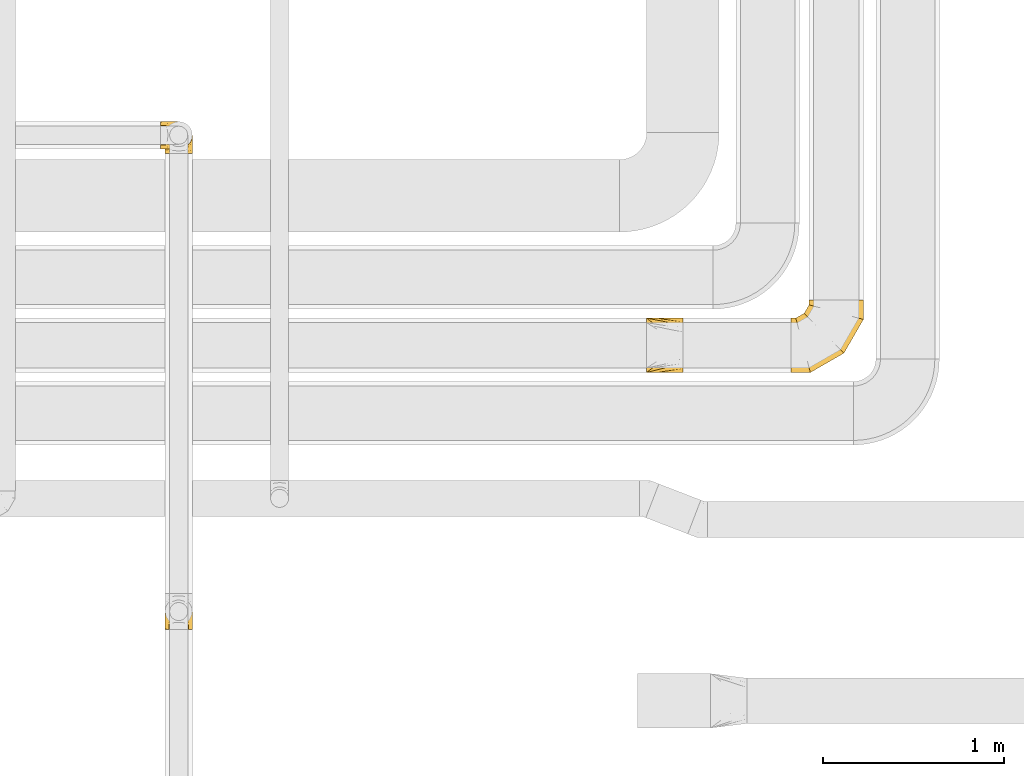
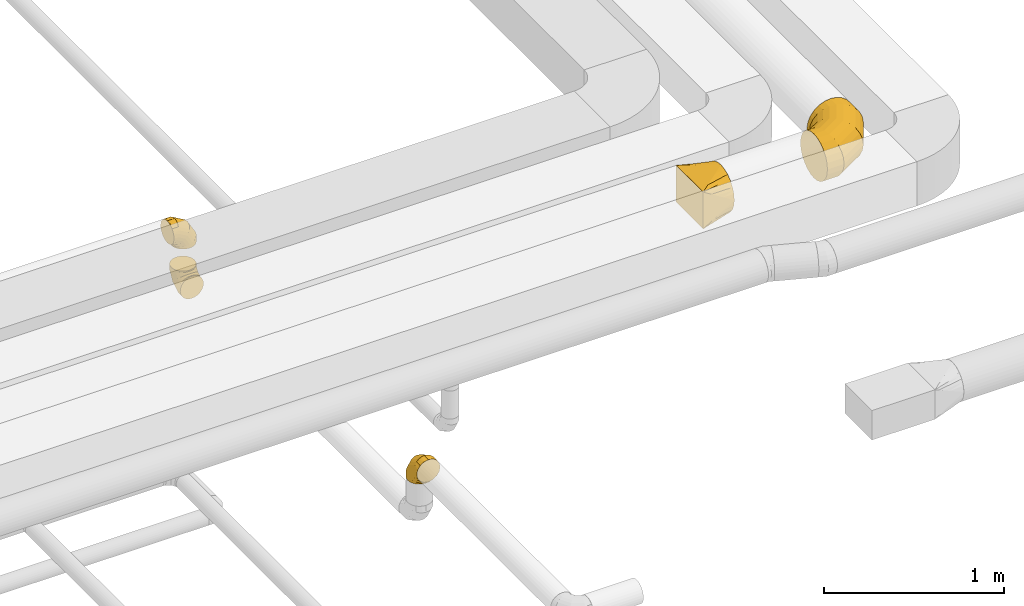
# One storey, part 10 of 92: 5 coverings.
"""IFC2X3 building model written with IfcOpenShell, lengths in millimetres."""

import ifcopenshell
import ifcopenshell.guid

model = None  # the IFC model being written
_history = None  # IfcOwnerHistory: only IFC2X3 demands one
_inside = {}  # id of a spatial element -> (the spatial element, [elements in it])
_under = {}  # id of a project, library or spatial element -> (it, [spatial elements below it])
_declared = {}  # id of a project -> (the project, [libraries it declares])
_typed = {}  # id of a type object -> (the type object, [elements of that type])
_made_of = {}  # id of a material, layer set ... -> (it, [elements and type objects made of it])


def new_model(schema):
    """Start an empty IFC model of exactly this schema.

    Asked for "IFC4X3", IfcOpenShell would pick the latest addendum, in which some entities
    have other attributes; the version numbers below select the first issue.
    IFC2X3 requires an IfcOwnerHistory on every rooted entity: one is made here for all.
    """
    global model, _history
    if schema == "IFC4X3":
        model = ifcopenshell.file(schema_version=(4, 3, 0, 0))
    else:
        model = ifcopenshell.file(schema=schema)
    _inside.clear()
    _under.clear()
    _declared.clear()
    _typed.clear()
    _made_of.clear()
    _history = None
    if model.schema == "IFC2X3":
        org = make("IfcOrganization", Name="unknown")
        user = make(
            "IfcPersonAndOrganization",
            ThePerson=make("IfcPerson", FamilyName="unknown"),
            TheOrganization=org,
        )
        app = make(
            "IfcApplication",
            ApplicationDeveloper=org,
            Version="unknown",
            ApplicationFullName="unknown",
            ApplicationIdentifier="unknown",
        )
        _history = make(
            "IfcOwnerHistory",
            OwningUser=user,
            OwningApplication=app,
            ChangeAction="ADDED",
            CreationDate=0,
        )
    return model


def make(cls, **values):
    """One entity of the class cls with the attributes given. An attribute that is None is left unset."""
    return model.create_entity(
        cls, **{name: value for name, value in values.items() if value is not None}
    )


def entity(cls, *values):
    """Any entity or typed value of the class cls, its attributes in the order of the schema. None: left unset."""
    e = model.create_entity(cls)
    for i, value in enumerate(values):
        if value is not None:
            e[i] = value
    return e


def rooted(cls, **values):
    """An entity with a GlobalId (a new one), such as an element, a storey or a relation."""
    return make(cls, GlobalId=ifcopenshell.guid.new(), OwnerHistory=_history, **values)


def si_unit(unit_type, name, prefix=None):
    """IfcSIUnit, for example si_unit("LENGTHUNIT", "METRE", prefix="MILLI")."""
    return make("IfcSIUnit", UnitType=unit_type, Prefix=prefix, Name=name)


def converted_unit(unit_type, name, factor, base, dimensions=None, offset=None):
    """IfcConversionBasedUnit, such as the inch: factor (a typed value) times the base unit."""
    return make(
        "IfcConversionBasedUnit"
        if offset is None
        else "IfcConversionBasedUnitWithOffset",
        ConversionOffset=offset,
        Dimensions=None
        if dimensions is None
        else entity("IfcDimensionalExponents", *dimensions),
        UnitType=unit_type,
        Name=name,
        ConversionFactor=make(
            "IfcMeasureWithUnit", ValueComponent=factor, UnitComponent=base
        ),
    )


def derived_unit(unit_type, elements):
    """IfcDerivedUnit: a product of units, each with its exponent."""
    return make(
        "IfcDerivedUnit",
        Elements=[
            make("IfcDerivedUnitElement", Unit=unit, Exponent=power)
            for unit, power in elements
        ],
        UnitType=unit_type,
    )


def assignment(units):
    """IfcUnitAssignment: the units of a project."""
    return None if units is None else make("IfcUnitAssignment", Units=units)


def point(xyz):
    """IfcCartesianPoint."""
    return None if xyz is None else make("IfcCartesianPoint", Coordinates=xyz)


def direction(xyz):
    """IfcDirection."""
    return None if xyz is None else make("IfcDirection", DirectionRatios=xyz)


def frame(location, z_axis=None, x_axis=None):
    """IfcAxis2Placement3D, a coordinate frame: its origin and axes. An axis left out is left unset."""
    return make(
        "IfcAxis2Placement3D",
        Location=point(location),
        Axis=direction(z_axis),
        RefDirection=direction(x_axis),
    )


def origin():
    """The frame at (0, 0, 0) with its axes left unset."""
    return frame((0.0, 0.0, 0.0))


def place(relative_to, where):
    """IfcLocalPlacement: puts the frame where relative to a parent placement (None: the world)."""
    return make(
        "IfcLocalPlacement", PlacementRelTo=relative_to, RelativePlacement=where
    )


def context(
    kind, dimensions, precision=None, world=None, true_north=None, identifier=None
):
    """IfcGeometricRepresentationContext, for example the 3D "Model" context."""
    return make(
        "IfcGeometricRepresentationContext",
        ContextIdentifier=identifier,
        ContextType=kind,
        CoordinateSpaceDimension=dimensions,
        Precision=precision,
        WorldCoordinateSystem=world,
        TrueNorth=true_north,
    )


def subcontext(parent, identifier, kind, view, scale=None):
    """IfcGeometricRepresentationSubContext, for example "Body" below "Model"."""
    return make(
        "IfcGeometricRepresentationSubContext",
        ContextIdentifier=identifier,
        ContextType=kind,
        ParentContext=parent,
        TargetScale=scale,
        TargetView=view,
    )


def project(units=None, contexts=None):
    """IfcProject with its units and contexts."""
    return rooted(
        "IfcProject",
        Name="project",
        RepresentationContexts=contexts,
        UnitsInContext=assignment(units),
    )


def spatial(cls, under=None, at=None, **own):
    """A site, building, storey or space (cls), placed at a placement, below another one or the project."""
    s = rooted(cls, ObjectPlacement=at, **own)
    if under is not None:
        _under.setdefault(under.id(), (under, []))[1].append(s)
    return s


def faces_of(points, faces, orient=None, outer=None):
    """IfcFace entities. A face is a list of loops; a loop is a list of indices into points, from 0.

    orient and outer hold one flag for each loop. By default every Orientation is true, the
    first loop of a face is its IfcFaceOuterBound and the others are IfcFaceBound.
    """
    made = []
    for i, loops in enumerate(faces):
        bounds = []
        for j, loop in enumerate(loops):
            is_outer = j == 0 if outer is None else outer[i][j]
            bounds.append(
                make(
                    "IfcFaceOuterBound" if is_outer else "IfcFaceBound",
                    Bound=make("IfcPolyLoop", Polygon=[points[k] for k in loop]),
                    Orientation=True if orient is None else orient[i][j],
                )
            )
        made.append(make("IfcFace", Bounds=bounds))
    return made


def faceted_brep(points, faces, orient=None, outer=None, voids=None):
    """IfcFacetedBrep: a solid bounded by flat faces; with voids (closed shells), ...WithVoids."""
    shared = [point(p) for p in points]
    hull = make("IfcClosedShell", CfsFaces=faces_of(shared, faces, orient, outer))
    if voids is None:
        return make("IfcFacetedBrep", Outer=hull)
    return make(
        "IfcFacetedBrepWithVoids",
        Outer=hull,
        Voids=[
            make(cls, CfsFaces=faces_of(shared, fs, o, b)) for cls, fs, o, b in voids
        ],
    )


def shape(context_of_items, identifier, shape_type, items):
    """IfcShapeRepresentation: the items that make up one representation, for example the "Body"."""
    return make(
        "IfcShapeRepresentation",
        ContextOfItems=context_of_items,
        RepresentationIdentifier=identifier,
        RepresentationType=shape_type,
        Items=items,
    )


def made_of(thing, what):
    """Note that an element or type object is made of a material, layer set ...; save() writes the relation."""
    if what is not None:
        _made_of.setdefault(what.id(), (what, []))[1].append(thing)
    return thing


def element(
    cls,
    number,
    at=None,
    inside=None,
    cuts=None,
    type_object=None,
    material=None,
    context=None,
    identifier="Body",
    shape_type=None,
    held_by="IfcProductDefinitionShape",
    body=None,
    shapes=None,
    **own,
):
    """One element of the class cls, such as IfcWall. Its Tag is "e" and its number.

    at: its placement. inside: the storey or other place that contains it. cuts: it is an
    opening in that element (IfcRelVoidsElement). A single representation is given by context,
    identifier, shape_type and body (its items); several are given by shapes. held_by: the class
    of the entity that holds the representations. save() writes the other relations.
    """
    e = rooted(cls, Tag="e%d" % number, ObjectPlacement=at, **own)
    if body is not None:
        shapes = [shape(context, identifier, shape_type, body)]
    if shapes is not None:
        e.Representation = make(held_by, Representations=shapes)
    if inside is not None:
        _inside.setdefault(inside.id(), (inside, []))[1].append(e)
    if cuts is not None:
        rooted(
            "IfcRelVoidsElement", RelatingBuildingElement=cuts, RelatedOpeningElement=e
        )
    if type_object is not None:
        _typed.setdefault(type_object.id(), (type_object, []))[1].append(e)
    return made_of(e, material)


def aggregate(whole, parts):
    """IfcRelAggregates: a whole, such as a stair, and the parts it consists of."""
    return rooted("IfcRelAggregates", RelatingObject=whole, RelatedObjects=parts)


def save(model, path):
    """Write the relations noted so far, then the file.

    IfcRelAggregates (storeys below a building ...), IfcRelContainedInSpatialStructure (elements
    in a storey), IfcRelDefinesByType, IfcRelAssociatesMaterial and IfcRelDeclares: one each for
    every whole, place, type object, material and project.
    """
    for whole, parts in _under.values():
        aggregate(whole, parts)
    for where, things in _inside.values():
        rooted(
            "IfcRelContainedInSpatialStructure",
            RelatedElements=things,
            RelatingStructure=where,
        )
    for kind, things in _typed.values():
        rooted("IfcRelDefinesByType", RelatedObjects=things, RelatingType=kind)
    for what, things in _made_of.values():
        rooted("IfcRelAssociatesMaterial", RelatedObjects=things, RelatingMaterial=what)
    for by, libraries in _declared.values():
        rooted("IfcRelDeclares", RelatingContext=by, RelatedDefinitions=libraries)
    model.write(path)


model = new_model("IFC2X3")

# Units and contexts
model_context = context("Model", 3, precision=0.01, world=origin(), true_north=direction((6.12303176911189e-17, 1.0)))
body_context = subcontext(model_context, "Body", "Model", "MODEL_VIEW")
ifc_project = project(units=[si_unit("LENGTHUNIT", "METRE", prefix="MILLI"), si_unit("AREAUNIT", "SQUARE_METRE"), si_unit("VOLUMEUNIT", "CUBIC_METRE"), converted_unit("PLANEANGLEUNIT", "DEGREE", entity("IfcRatioMeasure", 0.0174532925199433), si_unit("PLANEANGLEUNIT", "RADIAN"), dimensions=[0, 0, 0, 0, 0, 0, 0]), si_unit("MASSUNIT", "GRAM", prefix="KILO"), derived_unit("MASSDENSITYUNIT", [(si_unit("MASSUNIT", "GRAM", prefix="KILO"), 1), (si_unit("LENGTHUNIT", "METRE"), -3)]), derived_unit("MOMENTOFINERTIAUNIT", [(si_unit("LENGTHUNIT", "METRE"), 4)]), si_unit("TIMEUNIT", "SECOND"), si_unit("FREQUENCYUNIT", "HERTZ"), si_unit("THERMODYNAMICTEMPERATUREUNIT", "DEGREE_CELSIUS"), derived_unit("THERMALTRANSMITTANCEUNIT", [(si_unit("MASSUNIT", "GRAM", prefix="KILO"), 1), (si_unit("THERMODYNAMICTEMPERATUREUNIT", "KELVIN"), -1), (si_unit("TIMEUNIT", "SECOND"), -3)]), derived_unit("VOLUMETRICFLOWRATEUNIT", [(si_unit("LENGTHUNIT", "METRE"), 3), (si_unit("TIMEUNIT", "SECOND"), -1)]), derived_unit("MASSFLOWRATEUNIT", [(si_unit("MASSUNIT", "GRAM", prefix="KILO"), 1), (si_unit("TIMEUNIT", "SECOND"), -1)]), derived_unit("ROTATIONALFREQUENCYUNIT", [(si_unit("TIMEUNIT", "SECOND"), -1)]), si_unit("ELECTRICCURRENTUNIT", "AMPERE"), si_unit("ELECTRICVOLTAGEUNIT", "VOLT"), si_unit("POWERUNIT", "WATT"), si_unit("FORCEUNIT", "NEWTON", prefix="KILO"), si_unit("ILLUMINANCEUNIT", "LUX"), si_unit("LUMINOUSFLUXUNIT", "LUMEN"), si_unit("LUMINOUSINTENSITYUNIT", "CANDELA"), derived_unit("USERDEFINED", [(si_unit("MASSUNIT", "GRAM", prefix="KILO"), -1), (si_unit("LENGTHUNIT", "METRE"), -2), (si_unit("TIMEUNIT", "SECOND"), 3), (si_unit("LUMINOUSFLUXUNIT", "LUMEN"), 1)]), derived_unit("LINEARVELOCITYUNIT", [(si_unit("LENGTHUNIT", "METRE"), 1), (si_unit("TIMEUNIT", "SECOND"), -1)]), si_unit("PRESSUREUNIT", "PASCAL"), derived_unit("USERDEFINED", [(si_unit("LENGTHUNIT", "METRE"), -2), (si_unit("MASSUNIT", "GRAM", prefix="KILO"), 1), (si_unit("TIMEUNIT", "SECOND"), -2)]), derived_unit("LINEARFORCEUNIT", [(si_unit("MASSUNIT", "GRAM", prefix="KILO"), 1), (si_unit("LENGTHUNIT", "METRE"), 1), (si_unit("TIMEUNIT", "SECOND"), -2), (si_unit("LENGTHUNIT", "METRE"), -1)]), derived_unit("PLANARFORCEUNIT", [(si_unit("MASSUNIT", "GRAM", prefix="KILO"), 1), (si_unit("LENGTHUNIT", "METRE"), 1), (si_unit("TIMEUNIT", "SECOND"), -2), (si_unit("LENGTHUNIT", "METRE"), -2)])], contexts=[model_context])

# Site, building, storey
site_placement = place(None, origin())
site = spatial("IfcSite", under=ifc_project, at=site_placement, CompositionType="ELEMENT")
building_placement = place(site_placement, origin())
building = spatial("IfcBuilding", under=site, at=building_placement, CompositionType="ELEMENT")
storey_placement = place(building_placement, frame((0.0, 0.0, 4200.0)))
storey = spatial("IfcBuildingStorey", under=building, at=storey_placement, CompositionType="ELEMENT", Elevation=4200.0)

# Coverings
covering_1_placement = place(storey_placement, frame((22320.98, 12043.05, 3148.4)))
element("IfcCovering", 1, at=covering_1_placement, inside=storey, PredefinedType="INSULATION", context=body_context, shape_type="Brep", body=[
    faceted_brep([(356.07, 401.6, 257.66), (379.9, 401.6, 226.6), (394.89, 401.6, 190.42), (400.0, 401.6, 151.6), (394.89, 401.6, 112.77), (379.9, 401.6, 76.6), (356.07, 401.6, 45.53), (325.0, 401.6, 21.69), (288.82, 401.6, 6.71), (250.0, 401.6, 1.6), (211.18, 401.6, 6.71), (175.0, 401.6, 21.69), (143.93, 401.6, 45.53), (120.1, 401.6, 76.6), (105.11, 401.6, 112.77), (100.0, 401.6, 151.6), (105.11, 401.6, 190.42), (120.1, 401.6, 226.6), (143.93, 401.6, 257.66), (175.0, 401.6, 281.5), (211.18, 401.6, 296.48), (250.0, 401.6, 301.6), (288.82, 401.6, 296.48), (325.0, 401.6, 281.5), (0.0, 21.69, 76.6), (0.0, 6.71, 112.77), (0.0, 1.6, 151.6), (0.0, 6.71, 190.42), (0.0, 21.69, 226.6), (0.0, 45.53, 257.66), (0.0, 76.6, 281.5), (0.0, 112.77, 296.48), (0.0, 151.6, 301.6), (0.0, 190.42, 296.48), (0.0, 226.6, 281.5), (0.0, 257.66, 257.66), (0.0, 281.5, 226.6), (0.0, 296.48, 190.42), (0.0, 301.6, 151.6), (0.0, 296.48, 112.77), (0.0, 281.5, 76.6), (0.0, 257.66, 45.53), (0.0, 226.6, 21.69), (0.0, 190.42, 6.71), (0.0, 151.6, 1.6), (0.0, 112.77, 6.71), (0.0, 76.6, 21.69), (0.0, 45.53, 45.53), (107.18, 1.6, 151.6), (105.81, 6.71, 190.42), (101.79, 21.69, 226.6), (95.41, 45.53, 257.66), (87.08, 76.6, 281.5), (77.39, 112.77, 296.48), (66.99, 151.6, 301.6), (56.58, 190.42, 296.48), (46.89, 226.6, 281.5), (38.57, 257.66, 257.66), (32.18, 281.5, 226.6), (28.16, 296.48, 190.42), (26.79, 301.6, 151.6), (28.16, 296.48, 112.77), (32.18, 281.5, 76.6), (38.57, 257.66, 45.53), (56.58, 190.42, 6.71), (66.99, 151.6, 1.6), (46.89, 226.6, 21.69), (77.39, 112.77, 6.71), (87.08, 76.6, 21.69), (95.41, 45.53, 45.53), (101.79, 21.69, 76.6), (105.81, 6.71, 112.77), (292.82, 108.77, 151.6), (289.08, 112.52, 190.42), (278.11, 123.49, 226.6), (260.66, 140.94, 257.66), (237.92, 163.68, 281.5), (211.43, 190.16, 296.48), (183.01, 218.58, 301.6), (154.59, 247.0, 296.48), (128.11, 273.49, 281.5), (105.37, 296.23, 257.66), (87.92, 313.68, 226.6), (76.95, 324.65, 190.42), (73.21, 328.39, 151.6), (76.95, 324.65, 112.77), (87.92, 313.68, 76.6), (105.37, 296.23, 45.53), (154.59, 247.0, 6.71), (183.01, 218.58, 1.6), (128.11, 273.49, 21.69), (211.43, 190.16, 6.71), (237.92, 163.68, 21.69), (260.66, 140.94, 45.53), (278.11, 123.49, 76.6), (289.08, 112.52, 112.77), (400.0, 294.42, 151.6), (394.89, 295.79, 190.42), (379.9, 299.8, 226.6), (356.07, 306.19, 257.66), (325.0, 314.51, 281.5), (288.82, 324.21, 296.48), (250.0, 334.61, 301.6), (211.18, 345.01, 296.48), (175.0, 354.7, 281.5), (143.93, 363.03, 257.66), (120.1, 369.42, 226.6), (105.11, 373.43, 190.42), (100.0, 374.8, 151.6), (105.11, 373.43, 112.77), (120.1, 369.42, 76.6), (143.93, 363.03, 45.53), (211.18, 345.01, 6.71), (250.0, 334.61, 1.6), (175.0, 354.7, 21.69), (288.82, 324.21, 6.71), (325.0, 314.51, 21.69), (356.07, 306.19, 45.53), (379.9, 299.8, 76.6), (394.89, 295.79, 112.77)], [[[0, 1, 2, 3, 4, 5, 6, 7, 8, 9, 10, 11, 12, 13, 14, 15, 16, 17, 18, 19, 20, 21, 22, 23]], [[24, 25, 26, 27, 28, 29, 30, 31, 32, 33, 34, 35, 36, 37, 38, 39, 40, 41, 42, 43, 44, 45, 46, 47]], [[26, 48, 49, 27]], [[27, 49, 50, 28]], [[51, 29, 28, 50]], [[29, 51, 52, 30]], [[30, 52, 53, 31]], [[54, 32, 31, 53]], [[55, 56, 34, 33]], [[54, 55, 33, 32]], [[57, 35, 34, 56]], [[58, 59, 37, 36]], [[58, 36, 35, 57]], [[60, 38, 37, 59]], [[61, 62, 40, 39]], [[60, 61, 39, 38]], [[41, 40, 62, 63]], [[64, 65, 44, 43]], [[66, 64, 43, 42]], [[63, 66, 42, 41]], [[45, 44, 65, 67]], [[46, 45, 67, 68]], [[68, 69, 47, 46]], [[25, 24, 70, 71]], [[26, 25, 71, 48]], [[69, 70, 24, 47]], [[49, 48, 72, 73]], [[50, 49, 73, 74]], [[74, 75, 51, 50]], [[52, 51, 75, 76]], [[53, 52, 76, 77]], [[54, 53, 77, 78]], [[79, 80, 56, 55]], [[78, 79, 55, 54]], [[57, 56, 80, 81]], [[82, 83, 59, 58]], [[81, 82, 58, 57]], [[60, 59, 83, 84]], [[85, 86, 62, 61]], [[84, 85, 61, 60]], [[63, 62, 86, 87]], [[88, 89, 65, 64]], [[90, 88, 64, 66]], [[87, 90, 66, 63]], [[67, 65, 89, 91]], [[68, 67, 91, 92]], [[69, 68, 92, 93]], [[71, 70, 94, 95]], [[48, 71, 95, 72]], [[93, 94, 70, 69]], [[73, 72, 96, 97]], [[74, 73, 97, 98]], [[98, 99, 75, 74]], [[76, 75, 99, 100]], [[77, 76, 100, 101]], [[78, 77, 101, 102]], [[103, 104, 80, 79]], [[102, 103, 79, 78]], [[81, 80, 104, 105]], [[106, 107, 83, 82]], [[105, 106, 82, 81]], [[84, 83, 107, 108]], [[109, 110, 86, 85]], [[108, 109, 85, 84]], [[87, 86, 110, 111]], [[112, 113, 89, 88]], [[114, 112, 88, 90]], [[111, 114, 90, 87]], [[91, 89, 113, 115]], [[92, 91, 115, 116]], [[93, 92, 116, 117]], [[95, 94, 118, 119]], [[72, 95, 119, 96]], [[117, 118, 94, 93]], [[97, 96, 3, 2]], [[98, 97, 2, 1]], [[1, 0, 99, 98]], [[101, 100, 23, 22]], [[102, 101, 22, 21]], [[0, 23, 100, 99]], [[103, 102, 21, 20]], [[104, 103, 20, 19]], [[105, 104, 19, 18]], [[107, 106, 17, 16]], [[108, 107, 16, 15]], [[105, 18, 17, 106]], [[108, 15, 14, 109]], [[109, 14, 13, 110]], [[110, 13, 12, 111]], [[10, 9, 113, 112]], [[11, 10, 112, 114]], [[114, 111, 12, 11]], [[113, 9, 8, 115]], [[115, 8, 7, 116]], [[6, 117, 116, 7]], [[118, 5, 4, 119]], [[119, 4, 3, 96]], [[5, 118, 117, 6]]]),
])
covering_2_placement = place(storey_placement, frame((21524.05, 12043.05, 3148.4)))
element("IfcCovering", 2, at=covering_2_placement, inside=storey, PredefinedType="INSULATION", context=body_context, shape_type="Brep", body=[
    faceted_brep([(200.0, 269.58, 242.13), (200.0, 257.66, 257.66), (200.0, 242.13, 269.58), (200.0, 226.6, 281.5), (200.0, 208.51, 288.99), (200.0, 190.42, 296.48), (200.0, 178.2, 298.09), (200.0, 165.97, 299.7), (200.0, 151.6, 301.6), (200.0, 137.22, 299.7), (200.0, 124.99, 298.09), (200.0, 112.77, 296.48), (200.0, 94.68, 288.99), (200.0, 76.6, 281.5), (200.0, 61.06, 269.58), (200.0, 45.53, 257.66), (200.0, 33.61, 242.13), (200.0, 21.69, 226.6), (200.0, 14.2, 208.51), (200.0, 6.71, 190.42), (200.0, 5.1, 178.2), (200.0, 3.49, 165.97), (200.0, 1.6, 151.6), (200.0, 3.49, 137.22), (200.0, 5.1, 124.99), (200.0, 6.71, 112.77), (200.0, 14.2, 94.68), (200.0, 21.69, 76.6), (200.0, 33.61, 61.06), (200.0, 45.53, 45.53), (200.0, 61.06, 33.61), (200.0, 76.6, 21.69), (200.0, 94.68, 14.2), (200.0, 112.77, 6.71), (200.0, 124.99, 5.1), (200.0, 137.22, 3.49), (200.0, 151.6, 1.6), (200.0, 165.97, 3.49), (200.0, 178.2, 5.1), (200.0, 190.42, 6.71), (200.0, 208.51, 14.2), (200.0, 226.6, 21.69), (200.0, 242.13, 33.61), (200.0, 257.66, 45.53), (200.0, 269.58, 61.06), (200.0, 281.5, 76.6), (200.0, 288.99, 94.68), (200.0, 296.48, 112.77), (200.0, 298.09, 124.99), (200.0, 299.7, 137.22), (200.0, 301.6, 151.6), (200.0, 299.7, 165.97), (200.0, 298.09, 178.2), (200.0, 296.48, 190.42), (200.0, 288.99, 208.51), (200.0, 281.5, 226.6), (0.0, 301.6, 276.6), (0.0, 301.6, 26.6), (0.0, 1.6, 26.6), (0.0, 1.6, 276.6), (128.09, 205.53, 10.58), (104.11, 223.51, 13.58), (78.09, 243.03, 16.83), (100.0, 276.32, 32.95), (26.03, 282.07, 23.34), (52.06, 301.6, 59.13), (26.03, 301.6, 42.86), (78.09, 301.6, 75.4), (104.11, 301.6, 91.67), (128.09, 301.6, 106.65), (176.03, 169.57, 4.59), (152.06, 187.55, 7.59), (152.06, 301.6, 121.63), (176.03, 301.6, 136.61), (52.06, 262.55, 20.09), (26.03, 301.6, 260.33), (52.06, 301.6, 244.06), (78.09, 301.6, 227.79), (104.11, 301.6, 211.52), (128.09, 301.6, 196.54), (152.06, 301.6, 181.56), (176.03, 301.6, 166.58), (100.0, 282.74, 263.82), (52.06, 262.55, 283.1), (26.03, 282.07, 279.85), (78.09, 243.03, 286.36), (104.11, 223.51, 289.61), (128.09, 205.53, 292.61), (152.06, 187.55, 295.6), (176.03, 169.57, 298.6), (26.03, 21.12, 279.85), (52.06, 40.64, 283.1), (78.09, 60.16, 286.36), (104.11, 79.68, 289.61), (128.09, 97.66, 292.61), (152.06, 115.64, 295.6), (176.03, 133.62, 298.6), (100.0, 26.87, 270.24), (52.06, 1.6, 244.06), (26.03, 1.6, 260.33), (78.09, 1.6, 227.79), (104.11, 1.6, 211.52), (128.09, 1.6, 196.54), (152.06, 1.6, 181.56), (176.03, 1.6, 166.58), (26.03, 1.6, 42.86), (52.06, 1.6, 59.13), (78.09, 1.6, 75.4), (104.11, 1.6, 91.67), (128.09, 1.6, 106.65), (152.06, 1.6, 121.63), (176.03, 1.6, 136.61), (100.0, 20.45, 39.37), (52.06, 40.64, 20.09), (26.03, 21.12, 23.34), (78.09, 60.16, 16.83), (104.11, 79.68, 13.58), (128.09, 97.66, 10.58), (152.06, 115.64, 7.59), (176.03, 133.62, 4.59)], [[[0, 1, 2, 3, 4, 5, 6, 7, 8, 9, 10, 11, 12, 13, 14, 15, 16, 17, 18, 19, 20, 21, 22, 23, 24, 25, 26, 27, 28, 29, 30, 31, 32, 33, 34, 35, 36, 37, 38, 39, 40, 41, 42, 43, 44, 45, 46, 47, 48, 49, 50, 51, 52, 53, 54, 55]], [[56, 57, 58, 59]], [[60, 61, 62, 40]], [[63, 42, 64]], [[44, 43, 63]], [[39, 60, 40]], [[40, 62, 41]], [[65, 45, 44]], [[44, 63, 66]], [[46, 67, 68, 69]], [[70, 71, 60, 39, 38, 37, 36]], [[48, 47, 69, 72, 73, 50, 49]], [[46, 45, 67]], [[46, 69, 47]], [[45, 65, 67]], [[42, 74, 64]], [[42, 41, 74]], [[57, 63, 64]], [[42, 63, 43]], [[44, 66, 65]], [[63, 57, 66]], [[62, 74, 41]], [[57, 56, 75, 76, 77, 78, 79, 80, 81, 50, 73, 72, 69, 68, 67, 65, 66]], [[79, 78, 77, 54]], [[82, 0, 75]], [[2, 1, 82]], [[53, 79, 54]], [[54, 77, 55]], [[83, 3, 2]], [[2, 82, 84]], [[4, 85, 86, 87]], [[81, 80, 79, 53, 52, 51, 50]], [[6, 5, 87, 88, 89, 8, 7]], [[4, 3, 85]], [[4, 87, 5]], [[3, 83, 85]], [[0, 76, 75]], [[0, 55, 76]], [[56, 82, 75]], [[0, 82, 1]], [[2, 84, 83]], [[82, 56, 84]], [[77, 76, 55]], [[56, 59, 90, 91, 92, 93, 94, 95, 96, 8, 89, 88, 87, 86, 85, 83, 84]], [[94, 93, 92, 12]], [[97, 14, 90]], [[16, 15, 97]], [[11, 94, 12]], [[12, 92, 13]], [[98, 17, 16]], [[16, 97, 99]], [[18, 100, 101, 102]], [[96, 95, 94, 11, 10, 9, 8]], [[20, 19, 102, 103, 104, 22, 21]], [[18, 17, 100]], [[18, 102, 19]], [[17, 98, 100]], [[14, 91, 90]], [[14, 13, 91]], [[59, 97, 90]], [[14, 97, 15]], [[16, 99, 98]], [[97, 59, 99]], [[92, 91, 13]], [[59, 58, 105, 106, 107, 108, 109, 110, 111, 22, 104, 103, 102, 101, 100, 98, 99]], [[109, 108, 107, 26]], [[112, 28, 105]], [[30, 29, 112]], [[25, 109, 26]], [[26, 107, 27]], [[113, 31, 30]], [[30, 112, 114]], [[32, 115, 116, 117]], [[111, 110, 109, 25, 24, 23, 22]], [[34, 33, 117, 118, 119, 36, 35]], [[32, 31, 115]], [[32, 117, 33]], [[31, 113, 115]], [[28, 106, 105]], [[28, 27, 106]], [[58, 112, 105]], [[28, 112, 29]], [[30, 114, 113]], [[112, 58, 114]], [[107, 106, 27]], [[58, 57, 64, 74, 62, 61, 60, 71, 70, 36, 119, 118, 117, 116, 115, 113, 114]]]),
])
covering_3_placement = place(storey_placement, frame((18865.46, 13254.28, 2873.4)))
element("IfcCovering", 3, at=covering_3_placement, inside=storey, PredefinedType="INSULATION", context=body_context, shape_type="Brep", body=[
    faceted_brep([(105.3, 169.29, 176.6), (90.95, 172.15, 176.6), (76.6, 175.0, 176.6), (62.24, 172.15, 176.6), (47.89, 169.29, 176.6), (35.73, 161.16, 176.6), (23.56, 153.03, 176.6), (15.43, 140.87, 176.6), (7.3, 128.7, 176.6), (4.45, 114.35, 176.6), (1.6, 100.0, 176.6), (4.45, 85.65, 176.6), (7.3, 71.3, 176.6), (15.43, 59.13, 176.6), (23.56, 46.97, 176.6), (35.73, 38.84, 176.6), (47.89, 30.71, 176.6), (62.24, 27.85, 176.6), (69.42, 26.43, 176.6), (76.6, 25.0, 176.6), (83.77, 26.43, 176.6), (90.95, 27.85, 176.6), (105.3, 30.71, 176.6), (117.46, 38.84, 176.6), (129.63, 46.97, 176.6), (137.76, 59.13, 176.6), (145.89, 71.3, 176.6), (148.74, 85.65, 176.6), (151.6, 100.0, 176.6), (148.74, 114.35, 176.6), (145.89, 128.7, 176.6), (137.76, 140.87, 176.6), (129.63, 153.03, 176.6), (117.46, 161.16, 176.6), (57.18, 0.0, 4.15), (76.6, 0.0, 1.6), (96.01, 0.0, 4.15), (114.1, 0.0, 11.64), (129.63, 0.0, 23.56), (141.55, 0.0, 39.1), (149.04, 0.0, 57.18), (151.6, 0.0, 76.6), (149.04, 0.0, 96.01), (141.55, 0.0, 114.1), (129.63, 0.0, 129.63), (114.1, 0.0, 141.55), (96.01, 0.0, 149.04), (76.6, 0.0, 151.6), (57.18, 0.0, 149.04), (39.1, 0.0, 141.55), (23.56, 0.0, 129.63), (11.64, 0.0, 114.1), (4.15, 0.0, 96.01), (1.6, 0.0, 76.6), (4.15, 0.0, 57.18), (11.64, 0.0, 39.1), (23.56, 0.0, 23.56), (39.1, 0.0, 11.64), (76.6, 46.89, 1.6), (96.01, 46.21, 4.15), (114.1, 44.2, 11.64), (129.63, 41.01, 23.56), (141.55, 36.84, 39.1), (149.04, 32.0, 57.18), (151.6, 26.79, 76.6), (149.04, 21.59, 96.01), (141.55, 16.75, 114.1), (129.63, 12.58, 129.63), (114.1, 9.39, 141.55), (96.01, 7.38, 149.04), (76.6, 6.7, 151.6), (57.18, 7.38, 149.04), (39.1, 9.39, 141.55), (23.56, 12.58, 129.63), (4.15, 21.59, 96.01), (1.6, 26.79, 76.6), (11.64, 16.75, 114.1), (4.15, 32.0, 57.18), (11.64, 36.84, 39.1), (23.56, 41.01, 23.56), (39.1, 44.2, 11.64), (57.18, 46.21, 4.15), (76.6, 128.11, 48.49), (96.01, 126.24, 50.36), (114.1, 120.75, 55.84), (129.63, 112.03, 64.57), (141.55, 100.66, 75.94), (149.04, 87.42, 89.18), (151.6, 73.21, 103.39), (149.04, 58.99, 117.6), (141.55, 45.75, 130.84), (129.63, 34.38, 142.21), (114.1, 25.66, 150.94), (96.01, 20.17, 156.42), (76.6, 18.3, 158.29), (57.18, 20.17, 156.42), (39.1, 25.66, 150.94), (23.56, 34.38, 142.21), (4.15, 58.99, 117.6), (1.6, 73.21, 103.39), (11.64, 45.75, 130.84), (4.15, 87.42, 89.18), (11.64, 100.66, 75.94), (23.56, 112.03, 64.57), (39.1, 120.75, 55.84), (57.18, 126.24, 50.36), (76.6, 175.0, 129.7), (96.01, 172.44, 130.39), (114.1, 164.95, 132.4), (129.63, 153.03, 135.59), (141.55, 137.5, 139.75), (149.04, 119.41, 144.6), (151.6, 100.0, 149.8), (149.04, 80.59, 155.0), (141.55, 62.5, 159.85), (129.63, 46.97, 164.01), (114.1, 35.05, 167.2), (105.05, 31.3, 168.21), (96.01, 27.56, 169.21), (86.3, 26.28, 169.55), (76.6, 25.0, 169.9), (57.18, 27.56, 169.21), (48.14, 31.3, 168.21), (39.1, 35.05, 167.2), (66.89, 26.28, 169.55), (23.56, 46.97, 164.01), (4.15, 80.59, 155.0), (1.6, 100.0, 149.8), (11.64, 62.5, 159.85), (4.15, 119.41, 144.6), (11.64, 137.5, 139.75), (23.56, 153.03, 135.59), (39.1, 164.95, 132.4), (57.18, 172.44, 130.39)], [[[0, 1, 2, 3, 4, 5, 6, 7, 8, 9, 10, 11, 12, 13, 14, 15, 16, 17, 18, 19, 20, 21, 22, 23, 24, 25, 26, 27, 28, 29, 30, 31, 32, 33]], [[34, 35, 36, 37, 38, 39, 40, 41, 42, 43, 44, 45, 46, 47, 48, 49, 50, 51, 52, 53, 54, 55, 56, 57]], [[35, 58, 59, 36]], [[36, 59, 60, 37]], [[37, 60, 61, 38]], [[39, 62, 63, 40]], [[40, 63, 64, 41]], [[38, 61, 62, 39]], [[65, 66, 43, 42]], [[64, 65, 42, 41]], [[67, 44, 43, 66]], [[68, 69, 46, 45]], [[68, 45, 44, 67]], [[70, 47, 46, 69]], [[71, 72, 49, 48]], [[70, 71, 48, 47]], [[50, 49, 72, 73]], [[74, 75, 53, 52]], [[76, 74, 52, 51]], [[73, 76, 51, 50]], [[55, 54, 77, 78]], [[56, 55, 78, 79]], [[53, 75, 77, 54]], [[34, 57, 80, 81]], [[35, 34, 81, 58]], [[79, 80, 57, 56]], [[58, 82, 83, 59]], [[60, 59, 83, 84]], [[84, 85, 61, 60]], [[62, 61, 85, 86]], [[63, 62, 86, 87]], [[64, 63, 87, 88]], [[89, 90, 66, 65]], [[88, 89, 65, 64]], [[67, 66, 90, 91]], [[92, 93, 69, 68]], [[91, 92, 68, 67]], [[70, 69, 93, 94]], [[95, 96, 72, 71]], [[94, 95, 71, 70]], [[73, 72, 96, 97]], [[98, 99, 75, 74]], [[100, 98, 74, 76]], [[97, 100, 76, 73]], [[77, 75, 99, 101]], [[78, 77, 101, 102]], [[79, 78, 102, 103]], [[81, 80, 104, 105]], [[58, 81, 105, 82]], [[103, 104, 80, 79]], [[82, 106, 107, 83]], [[84, 83, 107, 108]], [[108, 109, 85, 84]], [[86, 85, 109, 110]], [[87, 86, 110, 111]], [[88, 87, 111, 112]], [[113, 114, 90, 89]], [[112, 113, 89, 88]], [[91, 90, 114, 115]], [[93, 92, 116, 117, 118]], [[115, 116, 92, 91]], [[94, 93, 118, 119, 120]], [[95, 121, 122, 123, 96]], [[94, 120, 124, 121, 95]], [[97, 96, 123, 125]], [[126, 127, 99, 98]], [[128, 126, 98, 100]], [[125, 128, 100, 97]], [[101, 99, 127, 129]], [[102, 101, 129, 130]], [[103, 102, 130, 131]], [[105, 104, 132, 133]], [[82, 105, 133, 106]], [[131, 132, 104, 103]], [[106, 1, 107]], [[111, 30, 29]], [[1, 106, 2]], [[32, 109, 33]], [[108, 0, 33]], [[107, 0, 108]], [[31, 30, 110]], [[108, 33, 109]], [[31, 109, 32]], [[28, 112, 29]], [[1, 0, 107]], [[112, 111, 29]], [[110, 30, 111]], [[109, 31, 110]], [[113, 28, 27, 26]], [[24, 115, 25]], [[119, 21, 20]], [[114, 26, 25]], [[114, 113, 26]], [[120, 20, 19]], [[114, 25, 115]], [[28, 113, 112]], [[120, 119, 20]], [[21, 119, 118]], [[22, 118, 117, 116]], [[24, 23, 115]], [[115, 23, 116]], [[118, 22, 21]], [[116, 23, 22]], [[121, 17, 16]], [[15, 14, 125]], [[16, 123, 122, 121]], [[18, 17, 124]], [[18, 120, 19]], [[125, 123, 15]], [[13, 125, 14]], [[126, 12, 11, 10]], [[125, 13, 128]], [[120, 18, 124]], [[126, 128, 12]], [[126, 10, 127]], [[17, 121, 124]], [[123, 16, 15]], [[13, 12, 128]], [[127, 9, 129]], [[6, 131, 7]], [[130, 8, 7]], [[129, 8, 130]], [[5, 131, 6]], [[9, 8, 129]], [[130, 7, 131]], [[9, 127, 10]], [[133, 4, 3]], [[131, 5, 132]], [[2, 106, 3]], [[4, 133, 132]], [[106, 133, 3]], [[5, 4, 132]]]),
])
covering_4_placement = place(storey_placement, frame((18842.06, 13277.68, 3200.0)))
element("IfcCovering", 4, at=covering_4_placement, inside=storey, PredefinedType="INSULATION", context=body_context, shape_type="Brep", body=[
    faceted_brep([(0.0, 47.89, 169.29), (0.0, 62.24, 172.15), (0.0, 76.6, 175.0), (0.0, 90.95, 172.15), (0.0, 105.3, 169.29), (0.0, 117.46, 161.16), (0.0, 129.63, 153.03), (0.0, 137.76, 140.87), (0.0, 145.89, 128.7), (0.0, 148.74, 114.35), (0.0, 151.6, 100.0), (0.0, 148.74, 85.65), (0.0, 145.89, 71.3), (0.0, 137.76, 59.13), (0.0, 129.63, 46.97), (0.0, 117.46, 38.84), (0.0, 105.3, 30.71), (0.0, 90.95, 27.85), (0.0, 83.77, 26.43), (0.0, 76.6, 25.0), (0.0, 69.42, 26.43), (0.0, 62.24, 27.85), (0.0, 47.89, 30.71), (0.0, 35.73, 38.84), (0.0, 23.56, 46.97), (0.0, 15.43, 59.13), (0.0, 7.3, 71.3), (0.0, 4.45, 85.65), (0.0, 1.6, 100.0), (0.0, 4.45, 114.35), (0.0, 7.3, 128.7), (0.0, 15.43, 140.87), (0.0, 23.56, 153.03), (0.0, 35.73, 161.16), (172.44, 96.01, 0.0), (175.0, 76.6, 0.0), (172.44, 57.18, 0.0), (164.95, 39.1, 0.0), (153.03, 23.56, 0.0), (137.5, 11.64, 0.0), (119.41, 4.15, 0.0), (100.0, 1.6, 0.0), (80.59, 4.15, 0.0), (62.5, 11.64, 0.0), (46.97, 23.56, 0.0), (35.05, 39.1, 0.0), (27.56, 57.18, 0.0), (25.0, 76.6, 0.0), (27.56, 96.01, 0.0), (35.05, 114.1, 0.0), (46.97, 129.63, 0.0), (62.5, 141.55, 0.0), (80.59, 149.04, 0.0), (100.0, 151.6, 0.0), (119.41, 149.04, 0.0), (137.5, 141.55, 0.0), (153.03, 129.63, 0.0), (164.95, 114.1, 0.0), (175.0, 76.6, 46.89), (172.44, 57.18, 46.21), (164.95, 39.1, 44.2), (153.03, 23.56, 41.01), (137.5, 11.64, 36.84), (119.41, 4.15, 32.0), (100.0, 1.6, 26.79), (80.59, 4.15, 21.59), (62.5, 11.64, 16.75), (46.97, 23.56, 12.58), (35.05, 39.1, 9.39), (27.56, 57.18, 7.38), (25.0, 76.6, 6.7), (27.56, 96.01, 7.38), (35.05, 114.1, 9.39), (46.97, 129.63, 12.58), (80.59, 149.04, 21.59), (100.0, 151.6, 26.79), (62.5, 141.55, 16.75), (119.41, 149.04, 32.0), (137.5, 141.55, 36.84), (153.03, 129.63, 41.01), (164.95, 114.1, 44.2), (172.44, 96.01, 46.21), (128.11, 76.6, 128.11), (126.24, 57.18, 126.24), (120.75, 39.1, 120.75), (112.03, 23.56, 112.03), (100.66, 11.64, 100.66), (87.42, 4.15, 87.42), (73.21, 1.6, 73.21), (58.99, 4.15, 58.99), (45.75, 11.64, 45.75), (34.38, 23.56, 34.38), (25.66, 39.1, 25.66), (20.17, 57.18, 20.17), (18.3, 76.6, 18.3), (20.17, 96.01, 20.17), (25.66, 114.1, 25.66), (34.38, 129.63, 34.38), (58.99, 149.04, 58.99), (73.21, 151.6, 73.21), (45.75, 141.55, 45.75), (87.42, 149.04, 87.42), (100.66, 141.55, 100.66), (112.03, 129.63, 112.03), (120.75, 114.1, 120.75), (126.24, 96.01, 126.24), (46.89, 76.6, 175.0), (46.21, 57.18, 172.44), (44.2, 39.1, 164.95), (41.01, 23.56, 153.03), (36.84, 11.64, 137.5), (32.0, 4.15, 119.41), (26.79, 1.6, 100.0), (21.59, 4.15, 80.59), (16.75, 11.64, 62.5), (12.58, 23.56, 46.97), (9.39, 39.1, 35.05), (8.39, 48.14, 31.3), (7.38, 57.18, 27.56), (7.04, 66.89, 26.28), (6.7, 76.6, 25.0), (7.38, 96.01, 27.56), (8.39, 105.05, 31.3), (9.39, 114.1, 35.05), (7.04, 86.3, 26.28), (12.58, 129.63, 46.97), (21.59, 149.04, 80.59), (26.79, 151.6, 100.0), (16.75, 141.55, 62.5), (32.0, 149.04, 119.41), (36.84, 141.55, 137.5), (41.01, 129.63, 153.03), (44.2, 114.1, 164.95), (46.21, 96.01, 172.44)], [[[0, 1, 2, 3, 4, 5, 6, 7, 8, 9, 10, 11, 12, 13, 14, 15, 16, 17, 18, 19, 20, 21, 22, 23, 24, 25, 26, 27, 28, 29, 30, 31, 32, 33]], [[34, 35, 36, 37, 38, 39, 40, 41, 42, 43, 44, 45, 46, 47, 48, 49, 50, 51, 52, 53, 54, 55, 56, 57]], [[35, 58, 59, 36]], [[36, 59, 60, 37]], [[37, 60, 61, 38]], [[39, 62, 63, 40]], [[40, 63, 64, 41]], [[38, 61, 62, 39]], [[65, 66, 43, 42]], [[64, 65, 42, 41]], [[67, 44, 43, 66]], [[68, 69, 46, 45]], [[68, 45, 44, 67]], [[70, 47, 46, 69]], [[71, 72, 49, 48]], [[70, 71, 48, 47]], [[50, 49, 72, 73]], [[74, 75, 53, 52]], [[76, 74, 52, 51]], [[73, 76, 51, 50]], [[55, 54, 77, 78]], [[56, 55, 78, 79]], [[53, 75, 77, 54]], [[34, 57, 80, 81]], [[35, 34, 81, 58]], [[79, 80, 57, 56]], [[58, 82, 83, 59]], [[60, 59, 83, 84]], [[84, 85, 61, 60]], [[62, 61, 85, 86]], [[63, 62, 86, 87]], [[64, 63, 87, 88]], [[89, 90, 66, 65]], [[88, 89, 65, 64]], [[67, 66, 90, 91]], [[92, 93, 69, 68]], [[91, 92, 68, 67]], [[70, 69, 93, 94]], [[95, 96, 72, 71]], [[94, 95, 71, 70]], [[73, 72, 96, 97]], [[98, 99, 75, 74]], [[100, 98, 74, 76]], [[97, 100, 76, 73]], [[77, 75, 99, 101]], [[78, 77, 101, 102]], [[79, 78, 102, 103]], [[81, 80, 104, 105]], [[58, 81, 105, 82]], [[103, 104, 80, 79]], [[82, 106, 107, 83]], [[84, 83, 107, 108]], [[108, 109, 85, 84]], [[86, 85, 109, 110]], [[87, 86, 110, 111]], [[88, 87, 111, 112]], [[113, 114, 90, 89]], [[112, 113, 89, 88]], [[91, 90, 114, 115]], [[93, 92, 116, 117, 118]], [[115, 116, 92, 91]], [[94, 93, 118, 119, 120]], [[95, 121, 122, 123, 96]], [[94, 120, 124, 121, 95]], [[97, 96, 123, 125]], [[126, 127, 99, 98]], [[128, 126, 98, 100]], [[125, 128, 100, 97]], [[101, 99, 127, 129]], [[102, 101, 129, 130]], [[103, 102, 130, 131]], [[105, 104, 132, 133]], [[82, 105, 133, 106]], [[131, 132, 104, 103]], [[106, 1, 107]], [[111, 30, 29]], [[1, 106, 2]], [[32, 109, 33]], [[108, 0, 33]], [[107, 0, 108]], [[31, 30, 110]], [[108, 33, 109]], [[31, 109, 32]], [[28, 112, 29]], [[1, 0, 107]], [[112, 111, 29]], [[110, 30, 111]], [[109, 31, 110]], [[113, 28, 27, 26]], [[24, 115, 25]], [[119, 21, 20]], [[114, 26, 25]], [[114, 113, 26]], [[120, 20, 19]], [[114, 25, 115]], [[28, 113, 112]], [[120, 119, 20]], [[21, 119, 118]], [[22, 118, 117, 116]], [[24, 23, 115]], [[115, 23, 116]], [[118, 22, 21]], [[116, 23, 22]], [[121, 17, 16]], [[15, 14, 125]], [[16, 123, 122, 121]], [[18, 17, 124]], [[18, 120, 19]], [[125, 123, 15]], [[13, 125, 14]], [[126, 12, 11, 10]], [[125, 13, 128]], [[120, 18, 124]], [[126, 128, 12]], [[126, 10, 127]], [[17, 121, 124]], [[123, 16, 15]], [[13, 12, 128]], [[127, 9, 129]], [[6, 131, 7]], [[130, 8, 7]], [[129, 8, 130]], [[5, 131, 6]], [[9, 8, 129]], [[130, 7, 131]], [[9, 127, 10]], [[133, 4, 3]], [[131, 5, 132]], [[2, 106, 3]], [[4, 133, 132]], [[106, 133, 3]], [[5, 4, 132]]]),
])
covering_5_placement = place(storey_placement, frame((18865.46, 10625.45, 3200.0)))
element("IfcCovering", 5, at=covering_5_placement, inside=storey, PredefinedType="INSULATION", context=body_context, shape_type="Brep", body=[
    faceted_brep([(105.3, 0.0, 169.29), (90.95, 0.0, 172.15), (76.6, 0.0, 175.0), (62.24, 0.0, 172.15), (47.89, 0.0, 169.29), (35.73, 0.0, 161.16), (23.56, 0.0, 153.03), (15.43, 0.0, 140.87), (7.3, 0.0, 128.7), (4.45, 0.0, 114.35), (1.6, 0.0, 100.0), (4.45, 0.0, 85.65), (7.3, 0.0, 71.3), (15.43, 0.0, 59.13), (23.56, 0.0, 46.97), (35.73, 0.0, 38.84), (47.89, 0.0, 30.71), (62.24, 0.0, 27.85), (69.42, 0.0, 26.43), (76.6, 0.0, 25.0), (83.77, 0.0, 26.43), (90.95, 0.0, 27.85), (105.3, 0.0, 30.71), (117.46, 0.0, 38.84), (129.63, 0.0, 46.97), (137.76, 0.0, 59.13), (145.89, 0.0, 71.3), (148.74, 0.0, 85.65), (151.6, 0.0, 100.0), (148.74, 0.0, 114.35), (145.89, 0.0, 128.7), (137.76, 0.0, 140.87), (129.63, 0.0, 153.03), (117.46, 0.0, 161.16), (57.18, 172.44, 0.0), (76.6, 175.0, 0.0), (96.01, 172.44, 0.0), (114.1, 164.95, 0.0), (129.63, 153.03, 0.0), (141.55, 137.5, 0.0), (149.04, 119.41, 0.0), (151.6, 100.0, 0.0), (149.04, 80.59, 0.0), (141.55, 62.5, 0.0), (129.63, 46.97, 0.0), (114.1, 35.05, 0.0), (96.01, 27.56, 0.0), (76.6, 25.0, 0.0), (57.18, 27.56, 0.0), (39.1, 35.05, 0.0), (23.56, 46.97, 0.0), (11.64, 62.5, 0.0), (4.15, 80.59, 0.0), (1.6, 100.0, 0.0), (4.15, 119.41, 0.0), (11.64, 137.5, 0.0), (23.56, 153.03, 0.0), (39.1, 164.95, 0.0), (76.6, 175.0, 46.89), (96.01, 172.44, 46.21), (114.1, 164.95, 44.2), (129.63, 153.03, 41.01), (141.55, 137.5, 36.84), (149.04, 119.41, 32.0), (151.6, 100.0, 26.79), (149.04, 80.59, 21.59), (141.55, 62.5, 16.75), (129.63, 46.97, 12.58), (114.1, 35.05, 9.39), (96.01, 27.56, 7.38), (76.6, 25.0, 6.7), (57.18, 27.56, 7.38), (39.1, 35.05, 9.39), (23.56, 46.97, 12.58), (4.15, 80.59, 21.59), (1.6, 100.0, 26.79), (11.64, 62.5, 16.75), (4.15, 119.41, 32.0), (11.64, 137.5, 36.84), (23.56, 153.03, 41.01), (39.1, 164.95, 44.2), (57.18, 172.44, 46.21), (76.6, 128.11, 128.11), (96.01, 126.24, 126.24), (114.1, 120.75, 120.75), (129.63, 112.03, 112.03), (141.55, 100.66, 100.66), (149.04, 87.42, 87.42), (151.6, 73.21, 73.21), (149.04, 58.99, 58.99), (141.55, 45.75, 45.75), (129.63, 34.38, 34.38), (114.1, 25.66, 25.66), (96.01, 20.17, 20.17), (76.6, 18.3, 18.3), (57.18, 20.17, 20.17), (39.1, 25.66, 25.66), (23.56, 34.38, 34.38), (4.15, 58.99, 58.99), (1.6, 73.21, 73.21), (11.64, 45.75, 45.75), (4.15, 87.42, 87.42), (11.64, 100.66, 100.66), (23.56, 112.03, 112.03), (39.1, 120.75, 120.75), (57.18, 126.24, 126.24), (76.6, 46.89, 175.0), (96.01, 46.21, 172.44), (114.1, 44.2, 164.95), (129.63, 41.01, 153.03), (141.55, 36.84, 137.5), (149.04, 32.0, 119.41), (151.6, 26.79, 100.0), (149.04, 21.59, 80.59), (141.55, 16.75, 62.5), (129.63, 12.58, 46.97), (114.1, 9.39, 35.05), (105.05, 8.39, 31.3), (96.01, 7.38, 27.56), (86.3, 7.04, 26.28), (76.6, 6.7, 25.0), (57.18, 7.38, 27.56), (48.14, 8.39, 31.3), (39.1, 9.39, 35.05), (66.89, 7.04, 26.28), (23.56, 12.58, 46.97), (4.15, 21.59, 80.59), (1.6, 26.79, 100.0), (11.64, 16.75, 62.5), (4.15, 32.0, 119.41), (11.64, 36.84, 137.5), (23.56, 41.01, 153.03), (39.1, 44.2, 164.95), (57.18, 46.21, 172.44)], [[[0, 1, 2, 3, 4, 5, 6, 7, 8, 9, 10, 11, 12, 13, 14, 15, 16, 17, 18, 19, 20, 21, 22, 23, 24, 25, 26, 27, 28, 29, 30, 31, 32, 33]], [[34, 35, 36, 37, 38, 39, 40, 41, 42, 43, 44, 45, 46, 47, 48, 49, 50, 51, 52, 53, 54, 55, 56, 57]], [[35, 58, 59, 36]], [[36, 59, 60, 37]], [[37, 60, 61, 38]], [[39, 62, 63, 40]], [[40, 63, 64, 41]], [[38, 61, 62, 39]], [[65, 66, 43, 42]], [[64, 65, 42, 41]], [[67, 44, 43, 66]], [[68, 69, 46, 45]], [[68, 45, 44, 67]], [[70, 47, 46, 69]], [[71, 72, 49, 48]], [[70, 71, 48, 47]], [[50, 49, 72, 73]], [[74, 75, 53, 52]], [[76, 74, 52, 51]], [[73, 76, 51, 50]], [[55, 54, 77, 78]], [[56, 55, 78, 79]], [[53, 75, 77, 54]], [[34, 57, 80, 81]], [[35, 34, 81, 58]], [[79, 80, 57, 56]], [[58, 82, 83, 59]], [[60, 59, 83, 84]], [[84, 85, 61, 60]], [[62, 61, 85, 86]], [[63, 62, 86, 87]], [[64, 63, 87, 88]], [[89, 90, 66, 65]], [[88, 89, 65, 64]], [[67, 66, 90, 91]], [[92, 93, 69, 68]], [[91, 92, 68, 67]], [[70, 69, 93, 94]], [[95, 96, 72, 71]], [[94, 95, 71, 70]], [[73, 72, 96, 97]], [[98, 99, 75, 74]], [[100, 98, 74, 76]], [[97, 100, 76, 73]], [[77, 75, 99, 101]], [[78, 77, 101, 102]], [[79, 78, 102, 103]], [[81, 80, 104, 105]], [[58, 81, 105, 82]], [[103, 104, 80, 79]], [[82, 106, 107, 83]], [[84, 83, 107, 108]], [[108, 109, 85, 84]], [[86, 85, 109, 110]], [[87, 86, 110, 111]], [[88, 87, 111, 112]], [[113, 114, 90, 89]], [[112, 113, 89, 88]], [[91, 90, 114, 115]], [[93, 92, 116, 117, 118]], [[115, 116, 92, 91]], [[94, 93, 118, 119, 120]], [[95, 121, 122, 123, 96]], [[94, 120, 124, 121, 95]], [[97, 96, 123, 125]], [[126, 127, 99, 98]], [[128, 126, 98, 100]], [[125, 128, 100, 97]], [[101, 99, 127, 129]], [[102, 101, 129, 130]], [[103, 102, 130, 131]], [[105, 104, 132, 133]], [[82, 105, 133, 106]], [[131, 132, 104, 103]], [[106, 1, 107]], [[111, 30, 29]], [[1, 106, 2]], [[32, 109, 33]], [[108, 0, 33]], [[107, 0, 108]], [[31, 30, 110]], [[108, 33, 109]], [[31, 109, 32]], [[28, 112, 29]], [[1, 0, 107]], [[112, 111, 29]], [[110, 30, 111]], [[109, 31, 110]], [[113, 28, 27, 26]], [[24, 115, 25]], [[119, 21, 20]], [[114, 26, 25]], [[114, 113, 26]], [[120, 20, 19]], [[114, 25, 115]], [[28, 113, 112]], [[120, 119, 20]], [[21, 119, 118]], [[22, 118, 117, 116]], [[24, 23, 115]], [[115, 23, 116]], [[118, 22, 21]], [[116, 23, 22]], [[121, 17, 16]], [[15, 14, 125]], [[16, 123, 122, 121]], [[18, 17, 124]], [[18, 120, 19]], [[125, 123, 15]], [[13, 125, 14]], [[126, 12, 11, 10]], [[125, 13, 128]], [[120, 18, 124]], [[126, 128, 12]], [[126, 10, 127]], [[17, 121, 124]], [[123, 16, 15]], [[13, 12, 128]], [[127, 9, 129]], [[6, 131, 7]], [[130, 8, 7]], [[129, 8, 130]], [[5, 131, 6]], [[9, 8, 129]], [[130, 7, 131]], [[9, 127, 10]], [[133, 4, 3]], [[131, 5, 132]], [[2, 106, 3]], [[4, 133, 132]], [[106, 133, 3]], [[5, 4, 132]]]),
])

save(model, "model.ifc")
